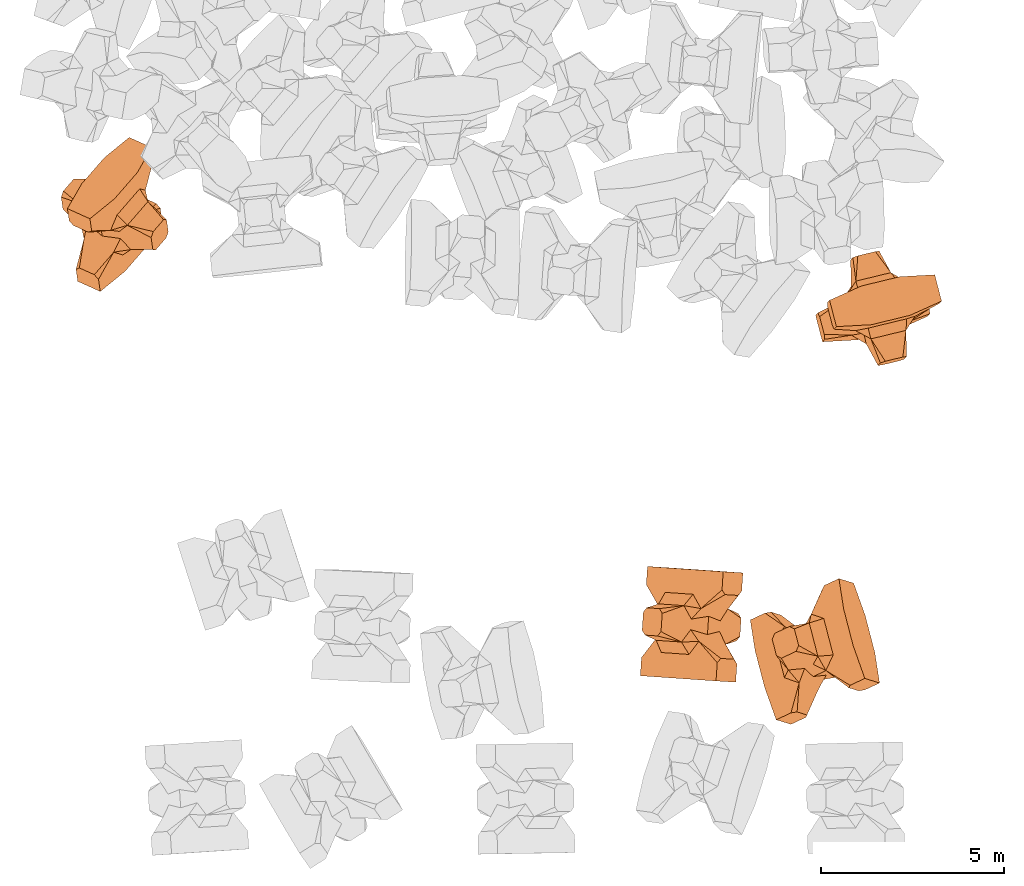
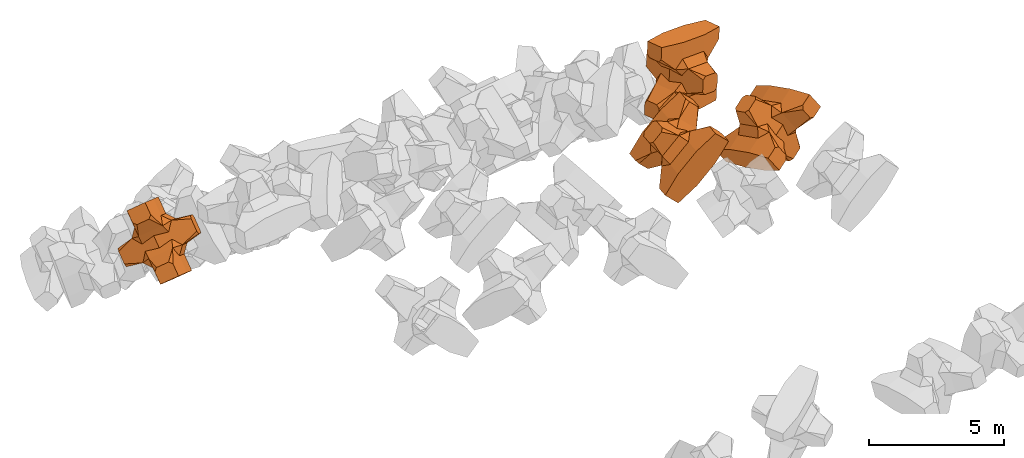
# One storey, part 10 of 17: 4 civil elements.
"""IFC4 building model written with IfcOpenShell, lengths in metres."""

from ifc_helpers import new_model, entity, si_unit, converted_unit, frame, origin_with_axes, origin_2d_with_axis, place, context, subcontext, project, spatial, polygons, element, save


model = new_model("IFC4")

# Units and contexts
model_context = context("Model", 3, precision=1e-05, world=origin_with_axes())
plan_context = context("Plan", 2, precision=1e-05, world=origin_2d_with_axis())
body_context = subcontext(model_context, "Body", "Model", "MODEL_VIEW")
ifc_project = project(units=[si_unit("VOLUMEUNIT", "CUBIC_METRE"), si_unit("LENGTHUNIT", "METRE"), converted_unit("PLANEANGLEUNIT", "degree", entity("IfcReal", 0.0174532925199433), si_unit("PLANEANGLEUNIT", "RADIAN"), dimensions=[0, 0, 0, 0, 0, 0, 0]), si_unit("AREAUNIT", "SQUARE_METRE")], contexts=[model_context, plan_context])

# Site, building, storey
site_placement = place(None, origin_with_axes())
site = spatial("IfcSite", under=ifc_project, at=site_placement)
building_placement = place(site_placement, origin_with_axes())
building = spatial("IfcBuilding", under=site, at=building_placement, Name="Building")
storey_placement = place(building_placement, origin_with_axes())
storey = spatial("IfcBuildingStorey", under=building, at=storey_placement, Name="Storey")

# Civil elements
civil_element_1_placement = place(storey_placement, frame((1.61697554588318, 13.6087913513184, 6.9821138381958), z_axis=(0.820624063401325, -0.370136533682965, 0.435402219792066), x_axis=(-0.563647321824041, -0.649859240387521, 0.509886913230315)))
element("IfcCivilElement", 1, at=civil_element_1_placement, inside=storey, ObjectType="IfcCivilElementType", context=body_context, shape_type="Tessellation", body=[
    polygons([(0.50000011920929, 0.500000059604645, 0.821428656578064), (0.374999821186066, 0.249999940395355, 1.5), (0.550000011920929, 0.145680621266365, 0.550000071525574), (0.374999821186066, -0.250000029802322, 1.5), (0.651315808296204, -0.250000029802322, 1.45970545872842e-07), (0.651315808296204, 0.249999940395355, 1.45970545872842e-07), (0.550000011920929, -0.145680695772171, 0.550000071525574), (0.50000011920929, -0.500000059604645, 0.821428656578064), (-0.25, 0.374999791383743, 1.5), (0.249999970197678, 0.374999791383743, 1.5), (-0.500000059604645, 0.500000059604645, 0.821428656578064), (-0.550000011920929, 0.824999988079071, 0.550000071525574), (0.550000011920929, 0.824999988079071, 0.550000071525574), (-0.550000011920929, 1.5, 0.550000071525574), (0.550000011920929, 1.5, 0.550000071525574), (-0.25, -0.375, 1.5), (0.249999970197678, -0.375, 1.5), (-0.374999970197678, -0.250000029802322, 1.5), (-0.374999970197678, 0.249999940395355, 1.5), (1.5, 0.87499988079071, -0.249999806284904), (1.5, 0.87499988079071, 0.25000011920929), (0.845557510852814, 0.449999898672104, -0.495555102825165), (0.845557510852814, 0.449999898672104, 0.495555102825165), (1.5, 1.5, -0.374999791383743), (1.5, 1.5, 0.374999940395355), (1.5, 1.0, -0.374999791383743), (1.5, 1.0, 0.374999940395355), (-1.5, 1.5, -0.374999791383743), (-1.5, 1.5, 0.374999940395355), (-0.550000011920929, 1.5, -0.54999977350235), (0.550000011920929, 1.5, -0.54999977350235), (0.550000011920929, 0.145680621266365, -0.54999977350235), (-0.500000059604645, -0.500000059604645, 0.821428656578064), (-0.550000011920929, -0.145680695772171, 0.550000071525574), (-0.651315808296204, 0.249999940395355, 1.45970545872842e-07), (-0.651315808296204, -0.250000029802322, 1.45970545872842e-07), (-0.550000011920929, 0.145680621266365, 0.550000071525574), (-1.5, 0.87499988079071, 0.25000011920929), (-1.5, 0.87499988079071, -0.249999806284904), (-0.845557391643524, 0.449999898672104, 0.495555102825165), (-0.845557391643524, 0.449999898672104, -0.495555102825165), (-1.5, 1.0, 0.374999940395355), (-1.5, 1.0, -0.374999791383743), (-0.550000011920929, 0.145680621266365, -0.54999977350235), (0.550000011920929, -0.825000107288361, 0.550000071525574), (-0.550000011920929, -0.825000107288361, 0.550000071525574), (0.550000011920929, -1.5, 0.550000071525574), (-0.550000011920929, -1.5, 0.550000071525574), (1.5, -0.875000059604645, 0.25000011920929), (1.5, -0.875000059604645, -0.249999806284904), (0.845557510852814, -0.450000137090683, 0.495555102825165), (0.845557510852814, -0.450000137090683, -0.495555102825165), (1.5, -1.5, 0.374999940395355), (1.5, -1.5, -0.374999791383743), (1.5, -1.00000011920929, 0.374999940395355), (1.5, -1.00000011920929, -0.374999791383743), (0.550000011920929, -1.5, -0.54999977350235), (-0.550000011920929, -1.5, -0.54999977350235), (-1.5, -1.5, -0.374999791383743), (-1.5, -1.5, 0.374999940395355), (0.550000011920929, -0.145680695772171, -0.54999977350235), (-1.5, -0.875000059604645, -0.249999806284904), (-1.5, -0.875000059604645, 0.25000011920929), (-0.845557391643524, -0.450000137090683, -0.495555102825165), (-0.845557391643524, -0.450000137090683, 0.495555102825165), (-1.5, -1.00000011920929, -0.374999791383743), (-1.5, -1.00000011920929, 0.374999940395355), (-0.550000011920929, -0.145680695772171, -0.54999977350235), (0.50000011920929, -0.500000059604645, -0.821428418159485), (0.374999821186066, -0.250000029802322, -1.49999976158142), (0.374999821186066, 0.249999940395355, -1.49999976158142), (0.50000011920929, 0.500000059604645, -0.821428418159485), (0.249999970197678, 0.374999791383743, -1.49999976158142), (-0.25, 0.374999791383743, -1.49999976158142), (-0.500000059604645, 0.500000059604645, -0.821428418159485), (0.550000011920929, 0.824999988079071, -0.54999977350235), (-0.550000011920929, 0.824999988079071, -0.54999977350235), (0.249999970197678, -0.375, -1.49999976158142), (-0.25, -0.375, -1.49999976158142), (-0.374999970197678, -0.250000029802322, -1.49999976158142), (-0.374999970197678, 0.249999940395355, -1.49999976158142), (-0.500000059604645, -0.500000059604645, -0.821428418159485), (-0.550000011920929, -0.825000107288361, -0.54999977350235), (0.550000011920929, -0.825000107288361, -0.54999977350235)], [[[1, 2, 3]], [[3, 2, 4]], [[5, 6, 7]], [[7, 6, 3]], [[7, 3, 8]], [[8, 3, 4]], [[9, 10, 11]], [[11, 10, 1]], [[12, 13, 14]], [[14, 13, 15]], [[16, 17, 18]], [[18, 17, 4]], [[18, 4, 19]], [[19, 4, 2]], [[19, 2, 9]], [[9, 2, 10]], [[20, 21, 22]], [[22, 21, 23]], [[24, 25, 26]], [[26, 25, 27]], [[26, 27, 20]], [[20, 27, 21]], [[23, 27, 13]], [[13, 27, 25]], [[13, 25, 15]], [[28, 29, 30]], [[30, 29, 14]], [[30, 14, 31]], [[31, 14, 15]], [[31, 15, 24]], [[24, 15, 25]], [[21, 27, 23]], [[2, 1, 10]], [[13, 12, 1]], [[1, 12, 11]], [[13, 1, 23]], [[32, 22, 6]], [[6, 22, 23]], [[6, 23, 3]], [[3, 23, 1]], [[33, 18, 34]], [[34, 18, 19]], [[35, 36, 37]], [[37, 36, 34]], [[37, 34, 11]], [[11, 34, 19]], [[38, 39, 40]], [[40, 39, 41]], [[29, 28, 42]], [[42, 28, 43]], [[42, 43, 38]], [[38, 43, 39]], [[14, 29, 12]], [[12, 29, 42]], [[12, 42, 40]], [[40, 42, 38]], [[9, 11, 19]], [[40, 11, 12]], [[37, 40, 35]], [[35, 40, 41]], [[35, 41, 44]], [[11, 40, 37]], [[17, 16, 8]], [[8, 16, 33]], [[45, 46, 47]], [[47, 46, 48]], [[49, 50, 51]], [[51, 50, 52]], [[53, 54, 55]], [[55, 54, 56]], [[55, 56, 49]], [[49, 56, 50]], [[47, 53, 45]], [[45, 53, 55]], [[45, 55, 51]], [[54, 53, 57]], [[57, 53, 47]], [[57, 47, 58]], [[58, 47, 48]], [[58, 48, 59]], [[59, 48, 60]], [[51, 55, 49]], [[17, 8, 4]], [[46, 45, 33]], [[33, 45, 8]], [[51, 8, 45]], [[7, 51, 5]], [[5, 51, 52]], [[5, 52, 61]], [[8, 51, 7]], [[62, 63, 64]], [[64, 63, 65]], [[59, 60, 66]], [[66, 60, 67]], [[66, 67, 62]], [[62, 67, 63]], [[65, 67, 46]], [[46, 67, 60]], [[46, 60, 48]], [[63, 67, 65]], [[18, 33, 16]], [[46, 33, 65]], [[68, 64, 36]], [[36, 64, 65]], [[36, 65, 34]], [[34, 65, 33]], [[69, 70, 61]], [[61, 70, 71]], [[6, 5, 32]], [[32, 5, 61]], [[32, 61, 72]], [[72, 61, 71]], [[73, 74, 72]], [[72, 74, 75]], [[76, 77, 31]], [[31, 77, 30]], [[78, 79, 70]], [[70, 79, 80]], [[70, 80, 71]], [[71, 80, 81]], [[71, 81, 73]], [[73, 81, 74]], [[31, 24, 76]], [[76, 24, 26]], [[76, 26, 22]], [[22, 26, 20]], [[73, 72, 71]], [[77, 76, 75]], [[75, 76, 72]], [[22, 72, 76]], [[72, 22, 32]], [[75, 81, 44]], [[44, 81, 80]], [[36, 35, 68]], [[68, 35, 44]], [[68, 44, 82]], [[82, 44, 80]], [[41, 43, 77]], [[77, 43, 28]], [[77, 28, 30]], [[39, 43, 41]], [[81, 75, 74]], [[77, 75, 41]], [[44, 41, 75]], [[79, 78, 82]], [[82, 78, 69]], [[83, 84, 58]], [[58, 84, 57]], [[52, 56, 84]], [[84, 56, 54]], [[84, 54, 57]], [[50, 56, 52]], [[70, 69, 78]], [[84, 83, 69]], [[69, 83, 82]], [[84, 69, 52]], [[61, 52, 69]], [[58, 59, 83]], [[83, 59, 66]], [[83, 66, 64]], [[64, 66, 62]], [[79, 82, 80]], [[64, 82, 83]], [[82, 64, 68]]], closed=True),
])
civil_element_2_placement = place(storey_placement, frame((22.5242042541504, 11.0405988693237, 8.92319965362549), z_axis=(0.250492180727279, -0.962595921855688, 0.103260634422277), x_axis=(0.959668118761625, 0.232827176264171, -0.15757096123771)))
element("IfcCivilElement", 2, at=civil_element_2_placement, inside=storey, ObjectType="IfcCivilElementType", context=body_context, shape_type="Tessellation", body=[
    polygons([(0.50000011920929, 0.500000596046448, 0.821430504322052), (0.374999821186066, 0.250000208616257, 1.5000034570694), (0.550000011920929, 0.145680785179138, 0.550001323223114), (0.374999821186066, -0.250000298023224, 1.5000034570694), (0.651315808296204, -0.250000298023224, 1.45970872722501e-07), (0.651315808296204, 0.250000208616257, 1.45970872722501e-07), (0.550000011920929, -0.145680859684944, 0.550001323223114), (0.50000011920929, -0.500000596046448, 0.821430504322052), (-0.25, 0.375000178813934, 1.5000034570694), (0.249999970197678, 0.375000178813934, 1.5000034570694), (-0.500000059604645, 0.500000596046448, 0.821430504322052), (-0.550000011920929, 0.825000882148743, 0.550001323223114), (0.550000011920929, 0.825000882148743, 0.550001323223114), (-0.550000011920929, 1.50000166893005, 0.550001323223114), (0.550000011920929, 1.50000166893005, 0.550001323223114), (-0.25, -0.375000417232513, 1.5000034570694), (0.249999970197678, -0.375000417232513, 1.5000034570694), (-0.374999970197678, -0.250000298023224, 1.5000034570694), (-0.374999970197678, 0.250000208616257, 1.5000034570694), (1.5, 0.875000774860382, -0.250000357627869), (1.5, 0.875000774860382, 0.250000655651093), (0.845557510852814, 0.450000375509262, -0.495556235313416), (0.845557510852814, 0.450000375509262, 0.495556235313416), (1.5, 1.50000166893005, -0.37500062584877), (1.5, 1.50000166893005, 0.375000774860382), (1.5, 1.00000107288361, -0.37500062584877), (1.5, 1.00000107288361, 0.375000774860382), (-1.5, 1.50000166893005, -0.37500062584877), (-1.5, 1.50000166893005, 0.375000774860382), (-0.550000011920929, 1.50000166893005, -0.55000102519989), (0.550000011920929, 1.50000166893005, -0.55000102519989), (0.550000011920929, 0.145680785179138, -0.55000102519989), (-0.500000059604645, -0.500000596046448, 0.821430504322052), (-0.550000011920929, -0.145680859684944, 0.550001323223114), (-0.651315808296204, 0.250000208616257, 1.45970872722501e-07), (-0.651315808296204, -0.250000298023224, 1.45970872722501e-07), (-0.550000011920929, 0.145680785179138, 0.550001323223114), (-1.5, 0.875000774860382, 0.250000655651093), (-1.5, 0.875000774860382, -0.250000357627869), (-0.845557391643524, 0.450000375509262, 0.495556235313416), (-0.845557391643524, 0.450000375509262, -0.495556235313416), (-1.5, 1.00000107288361, 0.375000774860382), (-1.5, 1.00000107288361, -0.37500062584877), (-0.550000011920929, 0.145680785179138, -0.55000102519989), (0.550000011920929, -0.825001001358032, 0.550001323223114), (-0.550000011920929, -0.825001001358032, 0.550001323223114), (0.550000011920929, -1.50000166893005, 0.550001323223114), (-0.550000011920929, -1.50000166893005, 0.550001323223114), (1.5, -0.875001013278961, 0.250000655651093), (1.5, -0.875001013278961, -0.250000357627869), (0.845557510852814, -0.450000613927841, 0.495556235313416), (0.845557510852814, -0.450000613927841, -0.495556235313416), (1.5, -1.50000166893005, 0.375000774860382), (1.5, -1.50000166893005, -0.37500062584877), (1.5, -1.0000011920929, 0.375000774860382), (1.5, -1.0000011920929, -0.37500062584877), (0.550000011920929, -1.50000166893005, -0.55000102519989), (-0.550000011920929, -1.50000166893005, -0.55000102519989), (-1.5, -1.50000166893005, -0.37500062584877), (-1.5, -1.50000166893005, 0.375000774860382), (0.550000011920929, -0.145680859684944, -0.55000102519989), (-1.5, -0.875001013278961, -0.250000357627869), (-1.5, -0.875001013278961, 0.250000655651093), (-0.845557391643524, -0.450000613927841, -0.495556235313416), (-0.845557391643524, -0.450000613927841, 0.495556235313416), (-1.5, -1.0000011920929, -0.37500062584877), (-1.5, -1.0000011920929, 0.375000774860382), (-0.550000011920929, -0.145680859684944, -0.55000102519989), (0.50000011920929, -0.500000596046448, -0.821430265903473), (0.374999821186066, -0.250000298023224, -1.50000309944153), (0.374999821186066, 0.250000208616257, -1.50000309944153), (0.50000011920929, 0.500000596046448, -0.821430265903473), (0.249999970197678, 0.375000178813934, -1.50000309944153), (-0.25, 0.375000178813934, -1.50000309944153), (-0.500000059604645, 0.500000596046448, -0.821430265903473), (0.550000011920929, 0.825000882148743, -0.55000102519989), (-0.550000011920929, 0.825000882148743, -0.55000102519989), (0.249999970197678, -0.375000417232513, -1.50000309944153), (-0.25, -0.375000417232513, -1.50000309944153), (-0.374999970197678, -0.250000298023224, -1.50000309944153), (-0.374999970197678, 0.250000208616257, -1.50000309944153), (-0.500000059604645, -0.500000596046448, -0.821430265903473), (-0.550000011920929, -0.825001001358032, -0.55000102519989), (0.550000011920929, -0.825001001358032, -0.55000102519989)], [[[1, 2, 3]], [[3, 2, 4]], [[5, 6, 7]], [[7, 6, 3]], [[7, 3, 8]], [[8, 3, 4]], [[9, 10, 11]], [[11, 10, 1]], [[12, 13, 14]], [[14, 13, 15]], [[16, 17, 18]], [[18, 17, 4]], [[18, 4, 19]], [[19, 4, 2]], [[19, 2, 9]], [[9, 2, 10]], [[20, 21, 22]], [[22, 21, 23]], [[24, 25, 26]], [[26, 25, 27]], [[26, 27, 20]], [[20, 27, 21]], [[23, 27, 13]], [[13, 27, 25]], [[13, 25, 15]], [[28, 29, 30]], [[30, 29, 14]], [[30, 14, 31]], [[31, 14, 15]], [[31, 15, 24]], [[24, 15, 25]], [[21, 27, 23]], [[2, 1, 10]], [[13, 12, 1]], [[1, 12, 11]], [[13, 1, 23]], [[32, 22, 6]], [[6, 22, 23]], [[6, 23, 3]], [[3, 23, 1]], [[33, 18, 34]], [[34, 18, 19]], [[35, 36, 37]], [[37, 36, 34]], [[37, 34, 11]], [[11, 34, 19]], [[38, 39, 40]], [[40, 39, 41]], [[29, 28, 42]], [[42, 28, 43]], [[42, 43, 38]], [[38, 43, 39]], [[14, 29, 12]], [[12, 29, 42]], [[12, 42, 40]], [[40, 42, 38]], [[9, 11, 19]], [[40, 11, 12]], [[37, 40, 35]], [[35, 40, 41]], [[35, 41, 44]], [[11, 40, 37]], [[17, 16, 8]], [[8, 16, 33]], [[45, 46, 47]], [[47, 46, 48]], [[49, 50, 51]], [[51, 50, 52]], [[53, 54, 55]], [[55, 54, 56]], [[55, 56, 49]], [[49, 56, 50]], [[47, 53, 45]], [[45, 53, 55]], [[45, 55, 51]], [[54, 53, 57]], [[57, 53, 47]], [[57, 47, 58]], [[58, 47, 48]], [[58, 48, 59]], [[59, 48, 60]], [[51, 55, 49]], [[17, 8, 4]], [[46, 45, 33]], [[33, 45, 8]], [[51, 8, 45]], [[7, 51, 5]], [[5, 51, 52]], [[5, 52, 61]], [[8, 51, 7]], [[62, 63, 64]], [[64, 63, 65]], [[59, 60, 66]], [[66, 60, 67]], [[66, 67, 62]], [[62, 67, 63]], [[65, 67, 46]], [[46, 67, 60]], [[46, 60, 48]], [[63, 67, 65]], [[18, 33, 16]], [[46, 33, 65]], [[68, 64, 36]], [[36, 64, 65]], [[36, 65, 34]], [[34, 65, 33]], [[69, 70, 61]], [[61, 70, 71]], [[6, 5, 32]], [[32, 5, 61]], [[32, 61, 72]], [[72, 61, 71]], [[73, 74, 72]], [[72, 74, 75]], [[76, 77, 31]], [[31, 77, 30]], [[78, 79, 70]], [[70, 79, 80]], [[70, 80, 71]], [[71, 80, 81]], [[71, 81, 73]], [[73, 81, 74]], [[31, 24, 76]], [[76, 24, 26]], [[76, 26, 22]], [[22, 26, 20]], [[73, 72, 71]], [[77, 76, 75]], [[75, 76, 72]], [[22, 72, 76]], [[72, 22, 32]], [[75, 81, 44]], [[44, 81, 80]], [[36, 35, 68]], [[68, 35, 44]], [[68, 44, 82]], [[82, 44, 80]], [[41, 43, 77]], [[77, 43, 28]], [[77, 28, 30]], [[39, 43, 41]], [[81, 75, 74]], [[77, 75, 41]], [[44, 41, 75]], [[79, 78, 82]], [[82, 78, 69]], [[83, 84, 58]], [[58, 84, 57]], [[52, 56, 84]], [[84, 56, 54]], [[84, 54, 57]], [[50, 56, 52]], [[70, 69, 78]], [[84, 83, 69]], [[69, 83, 82]], [[84, 69, 52]], [[61, 52, 69]], [[58, 59, 83]], [[83, 59, 66]], [[83, 66, 64]], [[64, 66, 62]], [[79, 82, 80]], [[64, 82, 83]], [[82, 64, 68]]], closed=True),
])
civil_element_3_placement = place(storey_placement, frame((17.4064788818359, 2.39098191261292, 12.4804611206055), z_axis=(0.719947768480886, -0.0450989686735826, -0.692561400659878), x_axis=(-0.690918098522452, 0.0477912172531155, -0.721351634563605)))
element("IfcCivilElement", 3, at=civil_element_3_placement, inside=storey, ObjectType="IfcCivilElementType", context=body_context, shape_type="Tessellation", body=[
    polygons([(0.500000059604645, 0.50000011920929, 0.821428656578064), (0.374999791383743, 0.249999970197678, 1.5), (0.549999952316284, 0.145680636167526, 0.550000071525574), (0.374999791383743, -0.250000029802322, 1.5), (0.651315748691559, -0.250000029802322, 1.45970545872842e-07), (0.651315748691559, 0.249999970197678, 1.45970545872842e-07), (0.549999952316284, -0.145680710673332, 0.550000071525574), (0.500000059604645, -0.50000011920929, 0.821428656578064), (-0.249999970197678, 0.374999821186066, 1.5), (0.249999940395355, 0.374999821186066, 1.5), (-0.5, 0.50000011920929, 0.821428656578064), (-0.549999952316284, 0.825000047683716, 0.550000071525574), (0.549999952316284, 0.825000047683716, 0.550000071525574), (-0.549999952316284, 1.50000023841858, 0.550000071525574), (0.549999952316284, 1.50000023841858, 0.550000071525574), (-0.249999970197678, -0.375000059604645, 1.5), (0.249999940395355, -0.375000059604645, 1.5), (-0.374999940395355, -0.250000029802322, 1.5), (-0.374999940395355, 0.249999970197678, 1.5), (1.49999988079071, 0.874999940395355, -0.249999806284904), (1.49999988079071, 0.874999940395355, 0.25000011920929), (0.845557451248169, 0.449999958276749, -0.495555102825165), (0.845557451248169, 0.449999958276749, 0.495555102825165), (1.49999988079071, 1.50000023841858, -0.374999791383743), (1.49999988079071, 1.50000023841858, 0.374999940395355), (1.49999988079071, 1.00000011920929, -0.374999791383743), (1.49999988079071, 1.00000011920929, 0.374999940395355), (-1.49999988079071, 1.50000023841858, -0.374999791383743), (-1.49999988079071, 1.50000023841858, 0.374999940395355), (-0.549999952316284, 1.50000023841858, -0.54999977350235), (0.549999952316284, 1.50000023841858, -0.54999977350235), (0.549999952316284, 0.145680636167526, -0.54999977350235), (-0.5, -0.50000011920929, 0.821428656578064), (-0.549999952316284, -0.145680710673332, 0.550000071525574), (-0.651315748691559, 0.249999970197678, 1.45970545872842e-07), (-0.651315748691559, -0.250000029802322, 1.45970545872842e-07), (-0.549999952316284, 0.145680636167526, 0.550000071525574), (-1.49999988079071, 0.874999940395355, 0.25000011920929), (-1.49999988079071, 0.874999940395355, -0.249999806284904), (-0.845557332038879, 0.449999958276749, 0.495555102825165), (-0.845557332038879, 0.449999958276749, -0.495555102825165), (-1.49999988079071, 1.00000011920929, 0.374999940395355), (-1.49999988079071, 1.00000011920929, -0.374999791383743), (-0.549999952316284, 0.145680636167526, -0.54999977350235), (0.549999952316284, -0.82500022649765, 0.550000071525574), (-0.549999952316284, -0.82500022649765, 0.550000071525574), (0.549999952316284, -1.50000023841858, 0.550000071525574), (-0.549999952316284, -1.50000023841858, 0.550000071525574), (1.49999988079071, -0.875000178813934, 0.25000011920929), (1.49999988079071, -0.875000178813934, -0.249999806284904), (0.845557451248169, -0.450000166893005, 0.495555102825165), (0.845557451248169, -0.450000166893005, -0.495555102825165), (1.49999988079071, -1.50000023841858, 0.374999940395355), (1.49999988079071, -1.50000023841858, -0.374999791383743), (1.49999988079071, -1.00000023841858, 0.374999940395355), (1.49999988079071, -1.00000023841858, -0.374999791383743), (0.549999952316284, -1.50000023841858, -0.54999977350235), (-0.549999952316284, -1.50000023841858, -0.54999977350235), (-1.49999988079071, -1.50000023841858, -0.374999791383743), (-1.49999988079071, -1.50000023841858, 0.374999940395355), (0.549999952316284, -0.145680710673332, -0.54999977350235), (-1.49999988079071, -0.875000178813934, -0.249999806284904), (-1.49999988079071, -0.875000178813934, 0.25000011920929), (-0.845557332038879, -0.450000166893005, -0.495555102825165), (-0.845557332038879, -0.450000166893005, 0.495555102825165), (-1.49999988079071, -1.00000023841858, -0.374999791383743), (-1.49999988079071, -1.00000023841858, 0.374999940395355), (-0.549999952316284, -0.145680710673332, -0.54999977350235), (0.500000059604645, -0.50000011920929, -0.821428418159485), (0.374999791383743, -0.250000029802322, -1.49999976158142), (0.374999791383743, 0.249999970197678, -1.49999976158142), (0.500000059604645, 0.50000011920929, -0.821428418159485), (0.249999940395355, 0.374999821186066, -1.49999976158142), (-0.249999970197678, 0.374999821186066, -1.49999976158142), (-0.5, 0.50000011920929, -0.821428418159485), (0.549999952316284, 0.825000047683716, -0.54999977350235), (-0.549999952316284, 0.825000047683716, -0.54999977350235), (0.249999940395355, -0.375000059604645, -1.49999976158142), (-0.249999970197678, -0.375000059604645, -1.49999976158142), (-0.374999940395355, -0.250000029802322, -1.49999976158142), (-0.374999940395355, 0.249999970197678, -1.49999976158142), (-0.5, -0.50000011920929, -0.821428418159485), (-0.549999952316284, -0.82500022649765, -0.54999977350235), (0.549999952316284, -0.82500022649765, -0.54999977350235)], [[[1, 2, 3]], [[3, 2, 4]], [[5, 6, 7]], [[7, 6, 3]], [[7, 3, 8]], [[8, 3, 4]], [[9, 10, 11]], [[11, 10, 1]], [[12, 13, 14]], [[14, 13, 15]], [[16, 17, 18]], [[18, 17, 4]], [[18, 4, 19]], [[19, 4, 2]], [[19, 2, 9]], [[9, 2, 10]], [[20, 21, 22]], [[22, 21, 23]], [[24, 25, 26]], [[26, 25, 27]], [[26, 27, 20]], [[20, 27, 21]], [[23, 27, 13]], [[13, 27, 25]], [[13, 25, 15]], [[28, 29, 30]], [[30, 29, 14]], [[30, 14, 31]], [[31, 14, 15]], [[31, 15, 24]], [[24, 15, 25]], [[21, 27, 23]], [[2, 1, 10]], [[13, 12, 1]], [[1, 12, 11]], [[13, 1, 23]], [[32, 22, 6]], [[6, 22, 23]], [[6, 23, 3]], [[3, 23, 1]], [[33, 18, 34]], [[34, 18, 19]], [[35, 36, 37]], [[37, 36, 34]], [[37, 34, 11]], [[11, 34, 19]], [[38, 39, 40]], [[40, 39, 41]], [[29, 28, 42]], [[42, 28, 43]], [[42, 43, 38]], [[38, 43, 39]], [[14, 29, 12]], [[12, 29, 42]], [[12, 42, 40]], [[40, 42, 38]], [[9, 11, 19]], [[40, 11, 12]], [[37, 40, 35]], [[35, 40, 41]], [[35, 41, 44]], [[11, 40, 37]], [[17, 16, 8]], [[8, 16, 33]], [[45, 46, 47]], [[47, 46, 48]], [[49, 50, 51]], [[51, 50, 52]], [[53, 54, 55]], [[55, 54, 56]], [[55, 56, 49]], [[49, 56, 50]], [[47, 53, 45]], [[45, 53, 55]], [[45, 55, 51]], [[54, 53, 57]], [[57, 53, 47]], [[57, 47, 58]], [[58, 47, 48]], [[58, 48, 59]], [[59, 48, 60]], [[51, 55, 49]], [[17, 8, 4]], [[46, 45, 33]], [[33, 45, 8]], [[51, 8, 45]], [[7, 51, 5]], [[5, 51, 52]], [[5, 52, 61]], [[8, 51, 7]], [[62, 63, 64]], [[64, 63, 65]], [[59, 60, 66]], [[66, 60, 67]], [[66, 67, 62]], [[62, 67, 63]], [[65, 67, 46]], [[46, 67, 60]], [[46, 60, 48]], [[63, 67, 65]], [[18, 33, 16]], [[46, 33, 65]], [[68, 64, 36]], [[36, 64, 65]], [[36, 65, 34]], [[34, 65, 33]], [[69, 70, 61]], [[61, 70, 71]], [[6, 5, 32]], [[32, 5, 61]], [[32, 61, 72]], [[72, 61, 71]], [[73, 74, 72]], [[72, 74, 75]], [[76, 77, 31]], [[31, 77, 30]], [[78, 79, 70]], [[70, 79, 80]], [[70, 80, 71]], [[71, 80, 81]], [[71, 81, 73]], [[73, 81, 74]], [[31, 24, 76]], [[76, 24, 26]], [[76, 26, 22]], [[22, 26, 20]], [[73, 72, 71]], [[77, 76, 75]], [[75, 76, 72]], [[22, 72, 76]], [[72, 22, 32]], [[75, 81, 44]], [[44, 81, 80]], [[36, 35, 68]], [[68, 35, 44]], [[68, 44, 82]], [[82, 44, 80]], [[41, 43, 77]], [[77, 43, 28]], [[77, 28, 30]], [[39, 43, 41]], [[81, 75, 74]], [[77, 75, 41]], [[44, 41, 75]], [[79, 78, 82]], [[82, 78, 69]], [[83, 84, 58]], [[58, 84, 57]], [[52, 56, 84]], [[84, 56, 54]], [[84, 54, 57]], [[50, 56, 52]], [[70, 69, 78]], [[84, 83, 69]], [[69, 83, 82]], [[84, 69, 52]], [[61, 52, 69]], [[58, 59, 83]], [[83, 59, 66]], [[83, 66, 64]], [[64, 66, 62]], [[79, 82, 80]], [[64, 82, 83]], [[82, 64, 68]]], closed=True),
])
civil_element_4_placement = place(storey_placement, frame((20.781436920166, 1.64790189266205, 12.6267137527466), z_axis=(0.538313208603586, -0.166521593493114, -0.826129195915159), x_axis=(-0.236510556556824, 0.911037074499056, -0.337748731345335)))
element("IfcCivilElement", 4, at=civil_element_4_placement, inside=storey, ObjectType="IfcCivilElementType", context=body_context, shape_type="Tessellation", body=[
    polygons([(0.499999970197678, 0.500000059604645, 0.821428656578064), (0.374999731779099, 0.249999940395355, 1.5), (0.549999833106995, 0.145680621266365, 0.550000071525574), (0.374999731779099, -0.250000029802322, 1.5), (0.651315629482269, -0.250000029802322, 1.45970545872842e-07), (0.651315629482269, 0.249999940395355, 1.45970545872842e-07), (0.549999833106995, -0.145680695772171, 0.550000071525574), (0.499999970197678, -0.500000059604645, 0.821428656578064), (-0.249999925494194, 0.374999791383743, 1.5), (0.249999895691872, 0.374999791383743, 1.5), (-0.49999988079071, 0.500000059604645, 0.821428656578064), (-0.549999833106995, 0.824999988079071, 0.550000071525574), (0.549999833106995, 0.824999988079071, 0.550000071525574), (-0.549999833106995, 1.5, 0.550000071525574), (0.549999833106995, 1.5, 0.550000071525574), (-0.249999925494194, -0.375, 1.5), (0.249999895691872, -0.375, 1.5), (-0.374999850988388, -0.250000029802322, 1.5), (-0.374999850988388, 0.249999940395355, 1.5), (1.49999964237213, 0.87499988079071, -0.249999806284904), (1.49999964237213, 0.87499988079071, 0.25000011920929), (0.845557272434235, 0.449999898672104, -0.495555102825165), (0.845557272434235, 0.449999898672104, 0.495555102825165), (1.49999964237213, 1.5, -0.374999791383743), (1.49999964237213, 1.5, 0.374999940395355), (1.49999964237213, 1.0, -0.374999791383743), (1.49999964237213, 1.0, 0.374999940395355), (-1.49999964237213, 1.5, -0.374999791383743), (-1.49999964237213, 1.5, 0.374999940395355), (-0.549999833106995, 1.5, -0.54999977350235), (0.549999833106995, 1.5, -0.54999977350235), (0.549999833106995, 0.145680621266365, -0.54999977350235), (-0.49999988079071, -0.500000059604645, 0.821428656578064), (-0.549999833106995, -0.145680695772171, 0.550000071525574), (-0.651315629482269, 0.249999940395355, 1.45970545872842e-07), (-0.651315629482269, -0.250000029802322, 1.45970545872842e-07), (-0.549999833106995, 0.145680621266365, 0.550000071525574), (-1.49999964237213, 0.87499988079071, 0.25000011920929), (-1.49999964237213, 0.87499988079071, -0.249999806284904), (-0.845557153224945, 0.449999898672104, 0.495555102825165), (-0.845557153224945, 0.449999898672104, -0.495555102825165), (-1.49999964237213, 1.0, 0.374999940395355), (-1.49999964237213, 1.0, -0.374999791383743), (-0.549999833106995, 0.145680621266365, -0.54999977350235), (0.549999833106995, -0.825000107288361, 0.550000071525574), (-0.549999833106995, -0.825000107288361, 0.550000071525574), (0.549999833106995, -1.5, 0.550000071525574), (-0.549999833106995, -1.5, 0.550000071525574), (1.49999964237213, -0.875000059604645, 0.25000011920929), (1.49999964237213, -0.875000059604645, -0.249999806284904), (0.845557272434235, -0.450000137090683, 0.495555102825165), (0.845557272434235, -0.450000137090683, -0.495555102825165), (1.49999964237213, -1.5, 0.374999940395355), (1.49999964237213, -1.5, -0.374999791383743), (1.49999964237213, -1.00000011920929, 0.374999940395355), (1.49999964237213, -1.00000011920929, -0.374999791383743), (0.549999833106995, -1.5, -0.54999977350235), (-0.549999833106995, -1.5, -0.54999977350235), (-1.49999964237213, -1.5, -0.374999791383743), (-1.49999964237213, -1.5, 0.374999940395355), (0.549999833106995, -0.145680695772171, -0.54999977350235), (-1.49999964237213, -0.875000059604645, -0.249999806284904), (-1.49999964237213, -0.875000059604645, 0.25000011920929), (-0.845557153224945, -0.450000137090683, -0.495555102825165), (-0.845557153224945, -0.450000137090683, 0.495555102825165), (-1.49999964237213, -1.00000011920929, -0.374999791383743), (-1.49999964237213, -1.00000011920929, 0.374999940395355), (-0.549999833106995, -0.145680695772171, -0.54999977350235), (0.499999970197678, -0.500000059604645, -0.821428418159485), (0.374999731779099, -0.250000029802322, -1.49999976158142), (0.374999731779099, 0.249999940395355, -1.49999976158142), (0.499999970197678, 0.500000059604645, -0.821428418159485), (0.249999895691872, 0.374999791383743, -1.49999976158142), (-0.249999925494194, 0.374999791383743, -1.49999976158142), (-0.49999988079071, 0.500000059604645, -0.821428418159485), (0.549999833106995, 0.824999988079071, -0.54999977350235), (-0.549999833106995, 0.824999988079071, -0.54999977350235), (0.249999895691872, -0.375, -1.49999976158142), (-0.249999925494194, -0.375, -1.49999976158142), (-0.374999850988388, -0.250000029802322, -1.49999976158142), (-0.374999850988388, 0.249999940395355, -1.49999976158142), (-0.49999988079071, -0.500000059604645, -0.821428418159485), (-0.549999833106995, -0.825000107288361, -0.54999977350235), (0.549999833106995, -0.825000107288361, -0.54999977350235)], [[[1, 2, 3]], [[3, 2, 4]], [[5, 6, 7]], [[7, 6, 3]], [[7, 3, 8]], [[8, 3, 4]], [[9, 10, 11]], [[11, 10, 1]], [[12, 13, 14]], [[14, 13, 15]], [[16, 17, 18]], [[18, 17, 4]], [[18, 4, 19]], [[19, 4, 2]], [[19, 2, 9]], [[9, 2, 10]], [[20, 21, 22]], [[22, 21, 23]], [[24, 25, 26]], [[26, 25, 27]], [[26, 27, 20]], [[20, 27, 21]], [[23, 27, 13]], [[13, 27, 25]], [[13, 25, 15]], [[28, 29, 30]], [[30, 29, 14]], [[30, 14, 31]], [[31, 14, 15]], [[31, 15, 24]], [[24, 15, 25]], [[21, 27, 23]], [[2, 1, 10]], [[13, 12, 1]], [[1, 12, 11]], [[13, 1, 23]], [[32, 22, 6]], [[6, 22, 23]], [[6, 23, 3]], [[3, 23, 1]], [[33, 18, 34]], [[34, 18, 19]], [[35, 36, 37]], [[37, 36, 34]], [[37, 34, 11]], [[11, 34, 19]], [[38, 39, 40]], [[40, 39, 41]], [[29, 28, 42]], [[42, 28, 43]], [[42, 43, 38]], [[38, 43, 39]], [[14, 29, 12]], [[12, 29, 42]], [[12, 42, 40]], [[40, 42, 38]], [[9, 11, 19]], [[40, 11, 12]], [[37, 40, 35]], [[35, 40, 41]], [[35, 41, 44]], [[11, 40, 37]], [[17, 16, 8]], [[8, 16, 33]], [[45, 46, 47]], [[47, 46, 48]], [[49, 50, 51]], [[51, 50, 52]], [[53, 54, 55]], [[55, 54, 56]], [[55, 56, 49]], [[49, 56, 50]], [[47, 53, 45]], [[45, 53, 55]], [[45, 55, 51]], [[54, 53, 57]], [[57, 53, 47]], [[57, 47, 58]], [[58, 47, 48]], [[58, 48, 59]], [[59, 48, 60]], [[51, 55, 49]], [[17, 8, 4]], [[46, 45, 33]], [[33, 45, 8]], [[51, 8, 45]], [[7, 51, 5]], [[5, 51, 52]], [[5, 52, 61]], [[8, 51, 7]], [[62, 63, 64]], [[64, 63, 65]], [[59, 60, 66]], [[66, 60, 67]], [[66, 67, 62]], [[62, 67, 63]], [[65, 67, 46]], [[46, 67, 60]], [[46, 60, 48]], [[63, 67, 65]], [[18, 33, 16]], [[46, 33, 65]], [[68, 64, 36]], [[36, 64, 65]], [[36, 65, 34]], [[34, 65, 33]], [[69, 70, 61]], [[61, 70, 71]], [[6, 5, 32]], [[32, 5, 61]], [[32, 61, 72]], [[72, 61, 71]], [[73, 74, 72]], [[72, 74, 75]], [[76, 77, 31]], [[31, 77, 30]], [[78, 79, 70]], [[70, 79, 80]], [[70, 80, 71]], [[71, 80, 81]], [[71, 81, 73]], [[73, 81, 74]], [[31, 24, 76]], [[76, 24, 26]], [[76, 26, 22]], [[22, 26, 20]], [[73, 72, 71]], [[77, 76, 75]], [[75, 76, 72]], [[22, 72, 76]], [[72, 22, 32]], [[75, 81, 44]], [[44, 81, 80]], [[36, 35, 68]], [[68, 35, 44]], [[68, 44, 82]], [[82, 44, 80]], [[41, 43, 77]], [[77, 43, 28]], [[77, 28, 30]], [[39, 43, 41]], [[81, 75, 74]], [[77, 75, 41]], [[44, 41, 75]], [[79, 78, 82]], [[82, 78, 69]], [[83, 84, 58]], [[58, 84, 57]], [[52, 56, 84]], [[84, 56, 54]], [[84, 54, 57]], [[50, 56, 52]], [[70, 69, 78]], [[84, 83, 69]], [[69, 83, 82]], [[84, 69, 52]], [[61, 52, 69]], [[58, 59, 83]], [[83, 59, 66]], [[83, 66, 64]], [[64, 66, 62]], [[79, 82, 80]], [[64, 82, 83]], [[82, 64, 68]]], closed=True),
])

save(model, "model.ifc")
